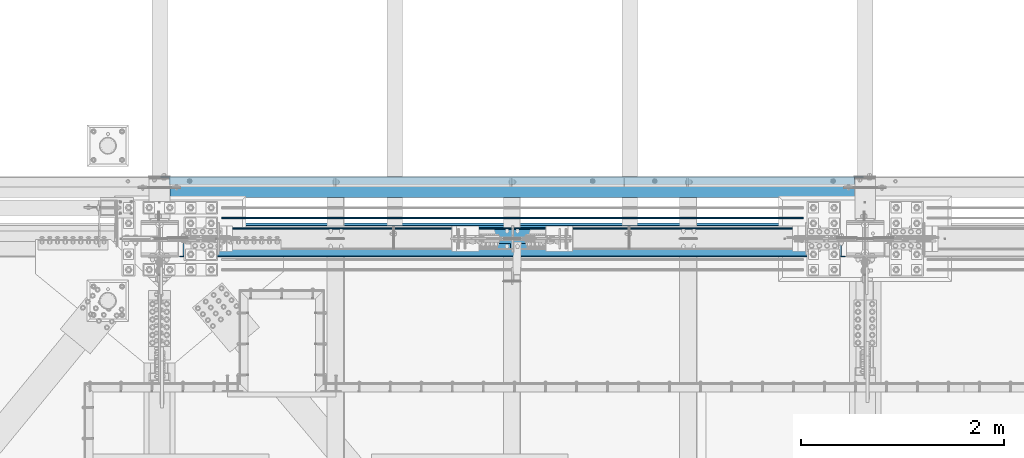
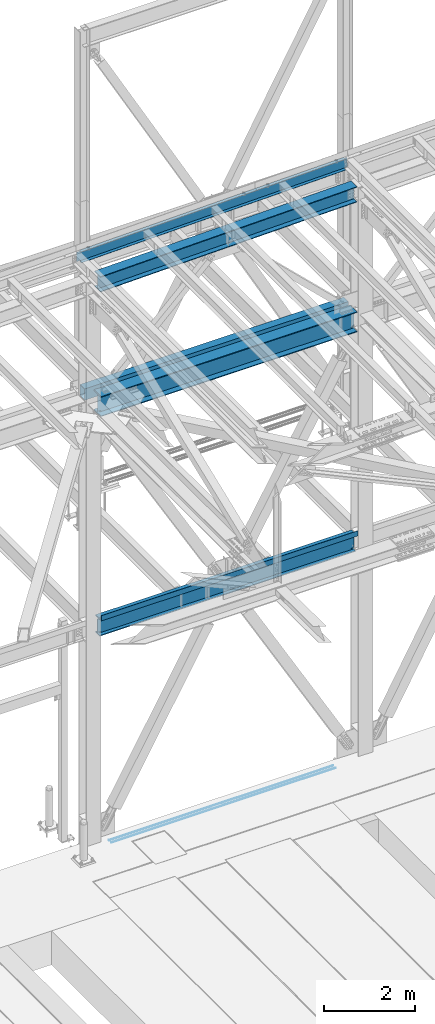
# One storey, part 1915 of 3843: 8 beams, 7 elements without a shape of their own.
"""IFC2X3 building model written with IfcOpenShell, lengths in millimetres."""

from ifc_helpers import new_model, si_unit, frame, origin_with_axes, place, context, subcontext, project, spatial, faceted_brep, material, type_object, element, aggregate, save


model = new_model("IFC2X3")

# Units and contexts
model_context = context("Model", 3, precision=1e-05, world=origin_with_axes())
body_context = subcontext(model_context, "Body", "Model", "MODEL_VIEW")
ifc_project = project(units=[si_unit("LENGTHUNIT", "METRE", prefix="MILLI"), si_unit("AREAUNIT", "SQUARE_METRE"), si_unit("VOLUMEUNIT", "CUBIC_METRE"), si_unit("MASSUNIT", "GRAM", prefix="KILO"), si_unit("TIMEUNIT", "SECOND"), si_unit("PLANEANGLEUNIT", "RADIAN"), si_unit("SOLIDANGLEUNIT", "STERADIAN"), si_unit("THERMODYNAMICTEMPERATUREUNIT", "DEGREE_CELSIUS"), si_unit("LUMINOUSINTENSITYUNIT", "LUMEN")], contexts=[model_context])

# Site, building, storey
site_placement = place(None, origin_with_axes())
site = spatial("IfcSite", under=ifc_project, at=site_placement, CompositionType="ELEMENT")
building_placement = place(site_placement, origin_with_axes())
building = spatial("IfcBuilding", under=site, at=building_placement, Name="Undefined", CompositionType="ELEMENT")
storey_placement = place(building_placement, origin_with_axes())
storey = spatial("IfcBuildingStorey", under=building, at=storey_placement, Name="Undefined", CompositionType="ELEMENT", Elevation=0.0)

# Assembly, beam
assembly_1_placement = place(storey_placement, origin_with_axes())
assembly_1 = element("IfcElementAssembly", 1, at=assembly_1_placement, inside=storey, Name="CHANNEL", AssemblyPlace="NOTDEFINED", PredefinedType="RIGID_FRAME")
ifc_material_1 = material(Name="STEEL/A572-50")
beam_type_1 = type_object("IfcBeamType", Name="C12X20.7", PredefinedType="NOTDEFINED")
beam_1_placement = place(assembly_1_placement, frame((48993.2421029154, 92786.1999989774, 45839.8700230406), z_axis=(-0.0211520980073474, 0.0, 0.999776269347241), x_axis=(0.999776270257024, 0.0, 0.0211520550054619)))
beam_1 = element("IfcBeam", 2, at=beam_1_placement, type_object=beam_type_1, material=ifc_material_1, Name="CHANNEL", ObjectType="C12X20.7", context=body_context, shape_type="Brep", body=[
    faceted_brep([(15.8751155402206, 30.1625000000058, -126.999999954867), (15.8750003662499, 38.1000000000058, -127.000000023749), (85.725000532555, 38.1000000000058, -127.000000023691), (85.725000532555, 30.1625000000058, -127.000000023691), (90.5850800505723, 38.1000000000058, -127.966729946267), (90.5850800505723, 30.1625000000058, -127.966729946267), (94.7052565187187, 38.1000000000058, -130.719743846734), (94.7052565187187, 30.1625000000058, -130.719743846734), (97.4582704191853, 38.1000000000058, -134.839920314858), (97.458270419178, 30.1625000000058, -134.674927499669), (98.4250003417692, 1.00112811196595e-06, -139.699999832876), (98.4250003417692, 38.1000000000058, -139.699999832876), (98.4250003417837, 38.1000000000058, -152.399999999638), (98.4250003417837, -38.1000000000058, -152.399999999638), (98.4250003417765, -38.1000000000058, -146.047459999652), (6837.32844832864, -38.1000000000058, 146.047460006623), (6837.32844832863, -38.1000000000058, 152.400000006615), (98.4250003414782, -38.1000000000058, 152.399999999863), (98.4250003414927, -38.1000000000058, 146.047459999871), (6837.32844832863, 38.1000000000058, 152.400000006615), (98.4250003414782, 38.1000000000058, 152.399999999863), (85.7250005323076, 30.1625000000058, 126.99999997508), (85.7250005323076, 38.1000000000058, 126.99999997508), (15.8750006201954, 38.1000000000058, 126.999999975014), (15.8751168099407, 30.1625000000058, 127.00000004391), (90.5850800503176, 30.1625000000058, 127.966729897671), (90.5850800503176, 38.1000000000058, 127.966729897671), (94.7052565184495, 30.1625000000058, 130.719743798138), (94.7052565184495, 38.1000000000058, 130.719743798138), (97.4582704189161, 30.1625000000058, 134.674927499887), (97.4582704189233, 38.1000000000058, 134.839920266269), (98.4250003414927, 1.29402906168252e-06, 139.699999784301), (98.4250003414927, 38.1000000000058, 139.699999784301), (6838.29517825124, 30.1625000000058, 134.674927506647), (6837.32844832865, 8.99206497706473e-07, 139.699999856828), (6837.32844832865, 38.1000000000058, 139.699999856828), (6838.29517825123, 38.1000000000058, 134.839920338811), (6841.04819215171, 30.1625000000058, 130.719743870679), (6841.04819215171, 38.1000000000058, 130.719743870679), (6845.16836861984, 30.1625000000058, 127.96672997022), (6845.16836861984, 38.1000000000058, 127.96672997022), (6850.02844813786, 30.1625000000058, 127.000000047636), (6850.02844813786, 38.1000000000058, 127.000000047636), (6919.87692259676, 30.1625000000058, 127.000000047708), (6919.87674203124, 38.1000000000058, 127.000000285479), (6919.87692244413, 30.1625000000058, 114.299999599563), (6919.87691967267, 30.1625000000058, -116.30000040507), (6919.87691954407, 30.1625000000058, -126.999999951055), (6919.87674076154, 38.1000000000058, -126.999999713284), (6850.02844813812, 30.1625000000058, -126.999999951135), (6850.02844813812, 38.1000000000058, -126.999999951135), (6845.1683686201, 30.1625000000058, -127.966729873719), (6845.1683686201, 38.1000000000058, -127.966729873719), (6841.04819215197, 30.1625000000058, -130.719743774185), (6841.04819215197, 38.1000000000058, -130.719743774185), (6838.29517825151, 30.1625000000058, -134.674927492917), (6838.29517825152, 38.1000000000058, -134.839920242324), (6837.32844832893, 1.395950675942e-06, -139.699999760349), (6837.32844832893, 38.1000000000058, -139.699999760349), (6837.32844832894, -38.1000000000058, -146.0474599929), (6837.32844832895, -38.1000000000058, -152.399999992893), (6837.32844832895, 38.1000000000058, -152.399999992893), (15.8751155937134, 30.1625000000058, -116.299999853079), (15.8751167464579, 30.1625000000058, 114.300000142401)], [[[0, 1, 2, 3]], [[3, 2, 4, 5]], [[5, 4, 6, 7]], [[7, 6, 8, 9]], [[10, 11, 12, 13, 14]], [[9, 8, 11, 10]], [[15, 16, 17, 18]], [[16, 19, 20, 17]], [[21, 22, 23, 24]], [[25, 26, 22, 21]], [[27, 28, 26, 25]], [[29, 30, 28, 27]], [[31, 32, 30, 29]], [[17, 20, 32, 31, 18]], [[29, 33, 34, 15, 18, 31]], [[16, 15, 34, 35, 19]], [[33, 36, 35, 34]], [[37, 38, 36, 33]], [[39, 40, 38, 37]], [[41, 42, 40, 39]], [[43, 44, 42, 41]], [[44, 43, 45, 46, 47, 48]], [[47, 49, 50, 48]], [[51, 52, 50, 49]], [[53, 54, 52, 51]], [[55, 56, 54, 53]], [[57, 58, 56, 55]], [[59, 60, 61, 58, 57]], [[60, 59, 14, 13]], [[61, 60, 13, 12]], [[6, 4, 2, 1, 23, 22, 26, 28, 30, 32, 20, 19, 35, 36, 38, 40, 42, 44, 48, 50, 52, 54, 56, 58, 61, 12, 11, 8]], [[62, 63, 24, 23, 1, 0]], [[55, 53, 51, 49, 47, 46, 45, 43, 41, 39, 37, 33, 29, 27, 25, 21, 24, 63, 62, 0, 3, 5, 7, 9]], [[59, 57, 55, 9, 10, 14]]]),
])
aggregate(assembly_1, [beam_1])

assembly_2_placement = place(storey_placement, origin_with_axes())
assembly_2 = element("IfcElementAssembly", 3, at=assembly_2_placement, inside=storey, Name="REBAR", AssemblyPlace="NOTDEFINED", PredefinedType="RIGID_FRAME")
ifc_material_2 = material(Name="STEEL/A706-60")
beam_type_2 = type_object("IfcBeamType", Name="#10 REBAR", PredefinedType="NOTDEFINED")
beam_2_placement = place(assembly_2_placement, frame((55321.2176583778, 92417.900012207, 30157.7375195987), z_axis=(-0.00222221699971851, 0.0, 0.999997530872755), x_axis=(-0.999997530872755, 0.0, -0.00222221699971722)))
beam_2 = element("IfcBeam", 4, at=beam_2_placement, type_object=beam_type_2, material=ifc_material_2, Name="REBAR", ObjectType="#10 REBAR", context=body_context, shape_type="Brep", body=[
    faceted_brep([(0.0, -7.9375, 0.0), (0.0, -5.61266007566883, -5.61266007566883), (5715.0141794653, -5.61266007566883, -5.61266008274833), (5715.0141794653, -7.9375, -7.09405867382884e-09), (0.0, 0.0, -7.9375), (5715.01417946529, 0.0, -7.93750000707951), (0.0, 5.61266007566883, -5.61266007566883), (5715.0141794653, 5.61266007566883, -5.61266008274833), (0.0, 7.9375, 0.0), (5715.0141794653, 7.9375, -7.09405867382884e-09), (0.0, 5.61266007566883, 5.61266007566883), (5715.0141794653, 5.61266007566883, 5.61266006856386), (0.0, 0.0, 7.9375), (5715.01417946531, 0.0, 7.93749999289503), (0.0, -5.61266007566883, 5.61266007566883), (5715.0141794653, -5.61266007566883, 5.61266006856386)], [[[0, 1, 2, 3]], [[1, 4, 5, 2]], [[4, 6, 7, 5]], [[6, 8, 9, 7]], [[8, 10, 11, 9]], [[10, 12, 13, 11]], [[12, 14, 15, 13]], [[14, 0, 3, 15]], [[5, 7, 9, 11, 13, 15, 3, 2]], [[14, 12, 10, 8, 6, 4, 1, 0]]]),
])
aggregate(assembly_2, [beam_2])

assembly_3_placement = place(storey_placement, origin_with_axes())
assembly_3 = element("IfcElementAssembly", 5, at=assembly_3_placement, inside=storey, Name="REBAR", AssemblyPlace="NOTDEFINED", PredefinedType="RIGID_FRAME")
beam_3_placement = place(assembly_3_placement, frame((55321.2176583778, 92316.300012207, 30157.7375195987), z_axis=(-0.00222221699971851, 0.0, 0.999997530872755), x_axis=(-0.999997530872755, 0.0, -0.00222221699971722)))
beam_3 = element("IfcBeam", 6, at=beam_3_placement, type_object=beam_type_2, material=ifc_material_2, Name="REBAR", ObjectType="#10 REBAR", context=body_context, shape_type="Brep", body=[
    faceted_brep([(0.0, -7.9375, 0.0), (0.0, -5.61266007566883, -5.61266007566883), (5715.0141794653, -5.61266007566883, -5.61266008274833), (5715.0141794653, -7.9375, -7.09405867382884e-09), (0.0, 0.0, -7.9375), (5715.01417946529, 0.0, -7.93750000707951), (0.0, 5.61266007566883, -5.61266007566883), (5715.0141794653, 5.61266007566883, -5.61266008274833), (0.0, 7.9375, 0.0), (5715.0141794653, 7.9375, -7.09405867382884e-09), (0.0, 5.61266007566883, 5.61266007566883), (5715.0141794653, 5.61266007566883, 5.61266006856386), (0.0, 0.0, 7.9375), (5715.01417946531, 0.0, 7.93749999289503), (0.0, -5.61266007566883, 5.61266007566883), (5715.0141794653, -5.61266007566883, 5.61266006856386)], [[[0, 1, 2, 3]], [[1, 4, 5, 2]], [[4, 6, 7, 5]], [[6, 8, 9, 7]], [[8, 10, 11, 9]], [[10, 12, 13, 11]], [[12, 14, 15, 13]], [[14, 0, 3, 15]], [[5, 7, 9, 11, 13, 15, 3, 2]], [[14, 12, 10, 8, 6, 4, 1, 0]]]),
])
aggregate(assembly_3, [beam_3])

assembly_4_placement = place(storey_placement, origin_with_axes())
assembly_4 = element("IfcElementAssembly", 7, at=assembly_4_placement, inside=storey, Name="BEAM", AssemblyPlace="NOTDEFINED", PredefinedType="RIGID_FRAME")
ifc_material_3 = material(Name="STEEL/A992")
beam_type_3 = type_object("IfcBeamType", Name="W21X101", PredefinedType="NOTDEFINED")
beam_4_placement = place(assembly_4_placement, frame((48996.6, 92214.6999998457, 42197.3375), z_axis=(0.0, 0.0, 1.0), x_axis=(1.0, 0.0, 0.0)))
beam_4 = element("IfcBeam", 8, at=beam_4_placement, type_object=beam_type_3, material=ifc_material_3, Name="BEAM", ObjectType="W21X101", context=body_context, shape_type="Brep", body=[
    faceted_brep([(201.007348416882, 6.35000000000582, 215.900000000001), (201.007348416882, 6.35000000000582, -215.900000000001), (193.674999999996, -6.35000000000582, -215.900000000001), (193.674999999996, -6.35000000000582, 215.900000000001), (270.487265581483, -6.35000000000036, -215.900000000001), (270.487265581483, 6.35000000000036, -215.900000000001), (275.550430772229, 6.35000000000036, -217.357163726287), (275.550430772229, -6.35000000000036, -217.357163726287), (279.064438807793, 6.35000000000036, -221.282812131343), (279.064438807793, -6.35000000000036, -221.282812131343), (279.954122181924, 6.35000000000036, -226.475829690324), (279.954122181924, -6.35000000000036, -226.475829690324), (277.94726789881, 6.35000000000036, -231.347328818971), (277.94726789881, -6.35000000000036, -231.347328818971), (273.657905435088, 6.35000000000036, -234.406795689014), (273.657905435088, -6.35000000000036, -234.406795689014), (228.27300000003, 6.35000000000036, -250.428), (228.27300000003, -6.35000000000036, -250.428), (205.818807990843, 6.35000000000036, -250.428), (205.818807990843, -6.35000000000036, -250.428), (6728.61038401834, 6.34999999999854, -250.824999999997), (6728.61038401834, 155.575000000001, -250.824999999997), (205.589615981677, 155.575000000001, -250.824999999997), (205.589615981677, 6.35000000000036, -250.824999999997), (6740.525, 155.575000000001, -271.462500000001), (193.675000000003, 155.575000000001, -271.462500000001), (6740.525, -155.575000000001, -271.462500000001), (193.675000000003, -155.575000000001, -271.462500000001), (6728.61038401834, -155.575000000001, -250.824999999997), (205.589615981677, -155.575000000001, -250.824999999997), (205.589615981677, -6.35000000000036, -250.824999999997), (6728.61038401834, -6.34999999999854, -250.824999999997), (6728.38119200916, 6.34999999999854, -250.428), (6728.38119200916, -6.34999999999854, -250.428), (6705.92699999999, 6.34999999999854, -250.428), (6705.92699999999, -6.34999999999854, -250.428), (6660.54209456492, 6.34999999999854, -234.406795689014), (6660.54209456492, -6.34999999999854, -234.406795689014), (6656.25273210119, 6.34999999999854, -231.347328818971), (6656.25273210119, -6.34999999999854, -231.347328818971), (6654.2458778181, 6.34999999999854, -226.475829690324), (6654.2458778181, -6.34999999999854, -226.475829690324), (6655.13556119223, 6.34999999999854, -221.282812131343), (6655.13556119223, -6.34999999999854, -221.282812131343), (6658.64956922777, 6.34999999999854, -217.357163726287), (6658.64956922777, -6.34999999999854, -217.357163726287), (6663.71273441853, 6.34999999999854, -215.900000000001), (6663.71273441853, -6.34999999999854, -215.900000000001), (6733.19265187846, 6.35000000000582, -215.900000000001), (6740.525, -6.35000000000582, -215.900000000001), (6740.525, -6.35000000000582, 215.900000000001), (6733.19265187846, 6.35000000000582, 215.900000000001), (6663.38573441853, 6.34999999999854, 215.900000000001), (6663.38573441853, -6.34999999999854, 215.900000000001), (6658.32256922778, 6.34999999999854, 217.357163726287), (6658.32256922778, -6.34999999999854, 217.357163726287), (6654.80856119223, 6.34999999999854, 221.282812131351), (6654.80856119223, -6.34999999999854, 221.282812131351), (6653.9188778181, 6.34999999999854, 226.475829690324), (6653.9188778181, -6.34999999999854, 226.475829690324), (6655.9257321012, 6.34999999999854, 231.347328818971), (6655.9257321012, -6.34999999999854, 231.347328818971), (6660.21509456492, 6.34999999999854, 234.406795689014), (6660.21509456492, -6.34999999999854, 234.406795689014), (6705.59999999999, 6.34999999999854, 250.428), (6705.59999999999, -6.34999999999854, 250.428), (6740.525, 6.34999999999854, 250.428), (6740.525, -6.34999999999854, 250.428), (6740.525, 6.34999999999854, 250.824999999997), (6740.525, -6.34999999999854, 250.824999999997), (6740.525, -155.575000000001, 250.824999999997), (6740.525, 155.575000000001, 250.824999999997), (6728.61039888389, 155.575000000001, 271.462500000001), (6728.61039888389, -155.575000000001, 271.462500000001), (193.675000000003, 6.35000000000036, 250.824999999997), (193.675000000003, 155.575000000001, 250.824999999997), (205.589601116109, 155.575000000001, 271.462500000001), (205.589601116109, -155.575000000001, 271.462500000001), (193.675000000003, -155.575000000001, 250.824999999997), (193.675000000003, -6.35000000000036, 250.824999999997), (193.675000000003, 6.35000000000036, 250.428), (193.675000000003, -6.35000000000036, 250.428), (228.60000000002, 6.35000000000036, 250.428), (228.60000000002, -6.35000000000036, 250.428), (273.984905435093, 6.35000000000036, 234.406795689014), (273.984905435093, -6.35000000000036, 234.406795689014), (278.274267898814, 6.35000000000036, 231.347328818971), (278.274267898814, -6.35000000000036, 231.347328818971), (280.281122181914, 6.35000000000036, 226.475829690324), (280.281122181914, -6.35000000000036, 226.475829690324), (279.391438807783, 6.35000000000036, 221.282812131351), (279.391438807783, -6.35000000000036, 221.282812131351), (275.877430772234, 6.35000000000036, 217.357163726287), (275.877430772234, -6.35000000000036, 217.357163726287), (270.814265581474, 6.35000000000036, 215.900000000001), (270.814265581474, -6.35000000000036, 215.900000000001)], [[[0, 1, 2, 3]], [[4, 5, 6, 7]], [[7, 6, 8, 9]], [[9, 8, 10, 11]], [[11, 10, 12, 13]], [[13, 12, 14, 15]], [[15, 14, 16, 17]], [[17, 16, 18, 19]], [[20, 21, 22, 23]], [[21, 24, 25, 22]], [[24, 26, 27, 25]], [[26, 28, 29, 27]], [[19, 18, 23, 22, 25, 27, 29, 30]], [[28, 31, 30, 29]], [[26, 24, 21, 20, 32, 33, 31, 28]], [[34, 35, 33, 32]], [[35, 34, 36, 37]], [[37, 36, 38, 39]], [[39, 38, 40, 41]], [[41, 40, 42, 43]], [[43, 42, 44, 45]], [[45, 44, 46, 47]], [[47, 46, 48, 49]], [[50, 49, 48, 51]], [[52, 53, 50, 51]], [[53, 52, 54, 55]], [[55, 54, 56, 57]], [[57, 56, 58, 59]], [[59, 58, 60, 61]], [[61, 60, 62, 63]], [[63, 62, 64, 65]], [[65, 64, 66, 67]], [[67, 66, 68, 69]], [[70, 69, 68, 71, 72, 73]], [[71, 68, 74, 75]], [[72, 71, 75, 76]], [[73, 72, 76, 77]], [[70, 73, 77, 78]], [[69, 70, 78, 79]], [[77, 76, 75, 74, 79, 78]], [[80, 81, 79, 74]], [[82, 83, 81, 80]], [[83, 82, 84, 85]], [[85, 84, 86, 87]], [[87, 86, 88, 89]], [[89, 88, 90, 91]], [[91, 90, 92, 93]], [[93, 92, 94, 95]], [[95, 94, 0, 3]], [[4, 7, 9, 11, 13, 15, 17, 19, 30, 31, 33, 35, 37, 39, 41, 43, 45, 47, 49, 50, 53, 55, 57, 59, 61, 63, 65, 67, 69, 79, 81, 83, 85, 87, 89, 91, 93, 95, 3, 2]], [[5, 4, 2, 1]], [[94, 92, 90, 88, 86, 84, 82, 80, 74, 68, 66, 64, 62, 60, 58, 56, 54, 52, 51, 48, 46, 44, 42, 40, 38, 36, 34, 32, 20, 23, 18, 16, 14, 12, 10, 8, 6, 5, 1, 0]]]),
])
aggregate(assembly_4, [beam_4])

assembly_5_placement = place(storey_placement, origin_with_axes())
assembly_5 = element("IfcElementAssembly", 9, at=assembly_5_placement, inside=storey, Name="GIRT", AssemblyPlace="NOTDEFINED", PredefinedType="RIGID_FRAME")
ifc_material_4 = material()
beam_type_4 = type_object("IfcBeamType", Name="HSS12X8X3/8", PredefinedType="NOTDEFINED")
beam_5_placement = place(assembly_5_placement, frame((48996.6, 92722.7, 42214.8), z_axis=(0.0, 0.0, 1.0), x_axis=(1.0, 0.0, 0.0)))
beam_5 = element("IfcBeam", 10, at=beam_5_placement, type_object=beam_type_4, material=ifc_material_4, Name="GIRT", ObjectType="HSS12X8X3/8", context=body_context, shape_type="Brep", body=[
    faceted_brep([(103.1875, 101.600000000006, -152.400000000001), (103.1875, 101.600000000006, 152.400000000001), (6831.0125, 101.600000000006, 152.400000000001), (6831.0125, 101.600000000006, -152.400000000001), (103.1875, -101.600000000006, -152.400000000001), (6831.0125, -101.600000000006, -152.400000000001), (103.1875, -101.600000000006, 152.400000000001), (6831.0125, -101.600000000006, 152.400000000001), (103.1875, 92.0749999999971, -142.875), (103.1875, 92.0749999999971, 142.875), (103.1875, -92.0749999999971, 142.875), (103.1875, -92.0749999999971, -142.875), (6831.0125, -92.0749999999971, 142.875), (6831.0125, -92.0749999999971, -142.875), (6831.0125, 92.0749999999971, -142.875), (6831.0125, 92.0749999999971, 142.875)], [[[0, 1, 2, 3]], [[4, 0, 3, 5]], [[6, 4, 5, 7]], [[1, 6, 7, 2]], [[0, 4, 6, 1], [8, 9, 10, 11]], [[11, 10, 12, 13]], [[8, 11, 13, 14]], [[9, 8, 14, 15]], [[10, 9, 15, 12]], [[3, 2, 7, 5], [14, 13, 12, 15]]]),
])
aggregate(assembly_5, [beam_5])

assembly_6_placement = place(storey_placement, origin_with_axes())
assembly_6 = element("IfcElementAssembly", 11, at=assembly_6_placement, inside=storey, Name="BEAM", AssemblyPlace="NOTDEFINED", PredefinedType="RIGID_FRAME")
beam_type_5 = type_object("IfcBeamType", Name="W18X65", PredefinedType="NOTDEFINED")
beam_6_placement = place(assembly_6_placement, frame((48996.6, 92214.7, 36202.9375), z_axis=(0.0, 0.0, 1.0), x_axis=(1.0, 0.0, 0.0)))
beam_6 = element("IfcBeam", 12, at=beam_6_placement, type_object=beam_type_5, material=ifc_material_3, Name="BEAM", ObjectType="W18X65", context=body_context, shape_type="Brep", body=[
    faceted_brep([(200.024999999994, -5.55625000000873, 179.387499999997), (193.674999999996, 5.55624999999418, 179.387499999997), (193.674999999996, 5.55624999999418, -179.387499999997), (200.024999999994, -5.55624999999418, -179.387499999997), (269.571265581471, -5.55624999999418, -179.387499999997), (269.571265581471, 5.55624999999418, -179.387499999997), (274.634430772225, 5.55624999999418, -180.844663726282), (274.634430772225, -5.55624999999418, -180.844663726282), (278.148438807781, 5.55624999999418, -184.770312131339), (278.148438807781, -5.55624999999418, -184.770312131339), (279.038122181912, 5.55624999999418, -189.963329690319), (279.038122181912, -5.55624999999418, -189.963329690319), (277.031267898805, 5.55624999999418, -194.834828818966), (277.031267898805, -5.55624999999418, -194.834828818966), (272.741905435083, 5.55624999999418, -197.89429568901), (272.741905435083, -5.55624999999418, -197.89429568901), (227.357000000004, 5.55624999999418, -213.915500000003), (227.357000000004, -5.55624999999418, -213.915500000003), (204.902798769261, 5.55624999999418, -213.915500000003), (204.902798769261, -5.55624999999418, -213.915500000003), (6729.52640246147, 5.55624999999418, -214.3125), (6729.52640246147, 96.8374999999942, -214.3125), (204.673597538524, 96.8374999999942, -214.3125), (204.673597538524, 5.55624999999418, -214.3125), (6740.525, 96.8374999999942, -233.362500000003), (193.674999999996, 96.8374999999942, -233.362500000003), (6740.525, -96.8374999999942, -233.362500000003), (193.674999999996, -96.8374999999942, -233.362500000003), (6729.52640246147, -96.8374999999942, -214.3125), (204.673597538524, -96.8374999999942, -214.3125), (204.673597538524, -5.55624999999418, -214.3125), (6729.52640246147, -5.55624999999418, -214.3125), (6729.29720123074, 5.55624999999418, -213.915500000003), (6729.29720123074, -5.55624999999418, -213.915500000003), (6706.84299999999, 5.55624999999418, -213.915500000003), (6706.84299999999, -5.55624999999418, -213.915500000003), (6661.45809456491, 5.55624999999418, -197.89429568901), (6661.45809456491, -5.55624999999418, -197.89429568901), (6657.16873210119, 5.55624999999418, -194.834828818966), (6657.16873210119, -5.55624999999418, -194.834828818966), (6655.16187781809, 5.55624999999418, -189.963329690319), (6655.16187781809, -5.55624999999418, -189.963329690319), (6656.05156119222, 5.55624999999418, -184.770312131339), (6656.05156119222, -5.55624999999418, -184.770312131339), (6659.56556922777, 5.55624999999418, -180.844663726282), (6659.56556922777, -5.55624999999418, -180.844663726282), (6664.62873441853, 5.55624999999418, -179.387499999997), (6664.62873441853, -5.55624999999418, -179.387499999997), (6740.525, 5.55624999999418, -179.387499999997), (6734.175, -5.55624999999418, -179.387499999997), (6740.525, 5.55624999999418, 179.387499999997), (6734.175, -5.55624999999418, 179.387499999997), (6663.38573441852, 5.55624999999418, 179.387499999997), (6663.38573441852, -5.55624999999418, 179.387499999997), (6658.32256922777, 5.55624999999418, 180.844663726282), (6658.32256922777, -5.55624999999418, 180.844663726282), (6654.80856119222, 5.55624999999418, 184.770312131339), (6654.80856119222, -5.55624999999418, 184.770312131339), (6653.91887781809, 5.55624999999418, 189.963329690319), (6653.91887781809, -5.55624999999418, 189.963329690319), (6655.92573210119, 5.55624999999418, 194.834828818966), (6655.92573210119, -5.55624999999418, 194.834828818966), (6660.21509456491, 5.55624999999418, 197.89429568901), (6660.21509456491, -5.55624999999418, 197.89429568901), (6705.59999999999, 5.55624999999418, 213.915500000003), (6705.59999999999, -5.55624999999418, 213.915500000003), (6740.525, 5.55624999999418, 213.915500000003), (6740.525, -5.55624999999418, 213.915500000003), (6740.525, 5.55624999999418, 214.3125), (6740.525, -5.55624999999418, 214.3125), (6740.525, -96.8374999999942, 214.3125), (6740.525, 96.8374999999942, 214.3125), (6729.52641847049, 96.8374999999942, 233.362500000003), (6729.52641847049, -96.8374999999942, 233.362500000003), (193.674999999996, 5.55624999999418, 214.3125), (193.674999999996, 96.8374999999942, 214.3125), (204.673581529503, 96.8374999999942, 233.362500000003), (204.673581529503, -96.8374999999942, 233.362500000003), (193.674999999996, -96.8374999999942, 214.3125), (193.674999999996, -5.55624999999418, 214.3125), (193.674999999996, 5.55624999999418, 213.915500000003), (193.674999999996, -5.55624999999418, 213.915500000003), (228.600000000006, 5.55624999999418, 213.915500000003), (228.600000000006, -5.55624999999418, 213.915500000003), (273.984905435085, 5.55624999999418, 197.89429568901), (273.984905435085, -5.55624999999418, 197.89429568901), (278.274267898807, 5.55624999999418, 194.834828818966), (278.274267898807, -5.55624999999418, 194.834828818966), (280.281122181907, 5.55624999999418, 189.963329690319), (280.281122181907, -5.55624999999418, 189.963329690319), (279.391438807776, 5.55624999999418, 184.770312131339), (279.391438807776, -5.55624999999418, 184.770312131339), (275.877430772227, 5.55624999999418, 180.844663726282), (275.877430772227, -5.55624999999418, 180.844663726282), (270.814265581474, 5.55624999999418, 179.387499999997), (270.814265581474, -5.55624999999418, 179.387499999997)], [[[0, 1, 2, 3]], [[4, 5, 6, 7]], [[7, 6, 8, 9]], [[9, 8, 10, 11]], [[11, 10, 12, 13]], [[13, 12, 14, 15]], [[15, 14, 16, 17]], [[17, 16, 18, 19]], [[20, 21, 22, 23]], [[21, 24, 25, 22]], [[24, 26, 27, 25]], [[26, 28, 29, 27]], [[19, 18, 23, 22, 25, 27, 29, 30]], [[28, 31, 30, 29]], [[26, 24, 21, 20, 32, 33, 31, 28]], [[34, 35, 33, 32]], [[35, 34, 36, 37]], [[37, 36, 38, 39]], [[39, 38, 40, 41]], [[41, 40, 42, 43]], [[43, 42, 44, 45]], [[45, 44, 46, 47]], [[47, 46, 48, 49]], [[50, 51, 49, 48]], [[52, 53, 51, 50]], [[53, 52, 54, 55]], [[55, 54, 56, 57]], [[57, 56, 58, 59]], [[59, 58, 60, 61]], [[61, 60, 62, 63]], [[63, 62, 64, 65]], [[65, 64, 66, 67]], [[67, 66, 68, 69]], [[70, 69, 68, 71, 72, 73]], [[71, 68, 74, 75]], [[72, 71, 75, 76]], [[73, 72, 76, 77]], [[70, 73, 77, 78]], [[69, 70, 78, 79]], [[77, 76, 75, 74, 79, 78]], [[80, 81, 79, 74]], [[82, 83, 81, 80]], [[83, 82, 84, 85]], [[85, 84, 86, 87]], [[87, 86, 88, 89]], [[89, 88, 90, 91]], [[91, 90, 92, 93]], [[93, 92, 94, 95]], [[4, 7, 9, 11, 13, 15, 17, 19, 30, 31, 33, 35, 37, 39, 41, 43, 45, 47, 49, 51, 53, 55, 57, 59, 61, 63, 65, 67, 69, 79, 81, 83, 85, 87, 89, 91, 93, 95, 0, 3]], [[5, 4, 3, 2]], [[94, 92, 90, 88, 86, 84, 82, 80, 74, 68, 66, 64, 62, 60, 58, 56, 54, 52, 50, 48, 46, 44, 42, 40, 38, 36, 34, 32, 20, 23, 18, 16, 14, 12, 10, 8, 6, 5, 2, 1]], [[95, 94, 1, 0]]]),
])

assembly_7_placement = place(storey_placement, origin_with_axes())
assembly_7 = element("IfcElementAssembly", 13, at=assembly_7_placement, inside=storey, Name="BEAM", AssemblyPlace="NOTDEFINED", PredefinedType="RIGID_FRAME")
beam_type_6 = type_object("IfcBeamType", Name="W16X67", PredefinedType="NOTDEFINED")
beam_7_placement = place(assembly_7_placement, frame((49000.9988430941, 92214.7, 45473.239573686), z_axis=(-0.0211520980073474, 0.0, 0.999776269347241), x_axis=(0.999776270257024, 0.0, 0.0211520550054619)))
beam_7 = element("IfcBeam", 14, at=beam_7_placement, type_object=beam_type_6, material=ifc_material_3, Name="BEAM", ObjectType="W16X67", context=body_context, shape_type="Brep", body=[
    faceted_brep([(188.094396478875, -130.174999999999, -207.962499999492), (188.094396478875, 130.174999999999, -207.962499999492), (6730.05803391119, 130.174999999999, -207.9624999929), (6730.05803391119, -130.174999999999, -207.9624999929), (188.463847647872, -130.174999999999, -190.49999999952), (188.463847647872, -4.76250000000073, -190.49999999952), (189.242288995723, -4.76249999999709, -153.706144372947), (195.989385218127, -4.76249999999709, 165.202490022399), (196.524600426201, -4.76250000000073, 190.499999999869), (196.524600426201, -130.174999999999, 190.499999999869), (196.894051595213, -130.174999999999, 207.962499999841), (196.894051595213, 130.174999999999, 207.962499999841), (196.524600426201, 130.174999999999, 190.499999999869), (196.524600426201, 4.76250000000073, 190.499999999869), (188.463847647872, 4.76250000000073, -190.49999999952), (188.463847647872, 130.174999999999, -190.49999999952), (6730.4274850802, -130.174999999999, -190.499999992935), (6730.4274850802, -4.76250000000073, -190.499999992935), (6731.16614278882, -4.76249999999709, -155.586565885453), (6737.91323901118, -4.76249999999709, 163.322068509893), (6738.48823785847, -4.76250000000073, 190.500000006461), (6738.48823785847, -130.174999999999, 190.500000006461), (6738.85768902747, -130.174999999999, 207.962500006433), (6738.85768902747, 130.174999999999, 207.962500006433), (6738.48823785847, 130.174999999999, 190.500000006461), (6738.48823785847, 4.76250000000073, 190.500000006461), (6730.4274850802, 4.76250000000073, -190.499999992935), (6730.4274850802, 130.174999999999, -190.499999992935)], [[[0, 1, 2, 3]], [[0, 4, 5, 6, 7, 8, 9, 10, 11, 12, 13, 14, 15, 1]], [[5, 4, 16, 17]], [[8, 7, 6, 5, 17, 18, 19, 20]], [[9, 8, 20, 21]], [[10, 9, 21, 22]], [[11, 10, 22, 23]], [[12, 11, 23, 24]], [[13, 12, 24, 25]], [[14, 13, 25, 26]], [[15, 14, 26, 27]], [[1, 15, 27, 2]], [[26, 25, 24, 23, 22, 21, 20, 19, 18, 17, 16, 3, 2, 27]], [[4, 0, 3, 16]]]),
])
aggregate(assembly_7, [beam_7])

# Beam
ifc_material_5 = material(Name="STEEL/A36")
beam_type_7 = type_object("IfcBeamType", PredefinedType="NOTDEFINED")
beam_8_placement = place(assembly_6_placement, frame((52463.7, 92168.662, 36439.475), z_axis=(-1.0, 0.0, 0.0), x_axis=(0.0, -1.0, 0.0)))
beam_8 = element("IfcBeam", 15, at=beam_8_placement, type_object=beam_type_7, material=ifc_material_5, Name="BENT_PLATE", context=body_context, shape_type="Brep", body=[
    faceted_brep([(125.411993408183, -3.17500000000291, 3236.91249999999), (125.411993408197, 3.17500000000291, 3236.91249999999), (0.0, 3.17500000000291, 3236.9125), (0.0, -3.17500000000291, 3236.9125), (125.411993408183, -3.17500000000291, 3273.42499999999), (125.411993408197, 3.17500000000291, 3273.425), (0.0, -3.17500000000291, 19.8437500000291), (0.0, 3.17500000000291, 19.8437500000291), (57.1490000000049, 3.17500000000291, 19.8437500000291), (57.1490000000049, -3.17500000000291, 19.8437500000291), (57.1494999999559, 3.17500000000291, -18.2562500000058), (57.1494999999559, -3.17500000000291, -18.2562500000058), (0.0, 3.17500000000291, -18.2562500000131), (0.0, -3.17500000000291, -18.2562500000131), (0.0, 3.17500000000291, -3236.91249999999), (0.0, -3.17500000000291, -3236.91249999999), (131.761993408203, -3.17500000000291, 3273.425), (131.761993408203, -3.17500000000291, -3273.425), (131.761993408203, 136.524996948239, -3273.425), (131.761993408203, 136.524996948239, 3273.425), (125.411993408183, -3.17500000000291, -3236.91250000001), (125.411993408183, -3.17500000000291, -3273.425), (125.411993408197, 3.17500000000291, -3236.91250000001), (125.411993408197, 3.17500000000291, -3273.425), (125.411993408197, 136.524996948239, -3273.425), (125.411993408197, 136.524996948239, 3236.91249999999), (125.411993408197, 136.524996948239, 3273.425), (125.411993408197, 136.524996948239, -3236.91250000001)], [[[0, 1, 2, 3]], [[4, 5, 1, 0]], [[6, 7, 8, 9]], [[9, 8, 10, 11]], [[11, 10, 12, 13]], [[14, 15, 13, 12]], [[16, 17, 18, 19]], [[3, 6, 9, 11, 13, 15, 20, 21, 17, 16, 4, 0]], [[7, 6, 3, 2]], [[22, 14, 12, 10, 8, 7, 2, 1]], [[15, 14, 22, 20]], [[20, 22, 23, 21]], [[24, 18, 17, 21, 23]], [[25, 26, 19, 18, 24, 27]], [[23, 22, 1, 5, 26, 25, 27, 24]], [[16, 19, 26, 5, 4]]]),
])

aggregate(assembly_6, [beam_8, beam_6])

save(model, "model.ifc")
